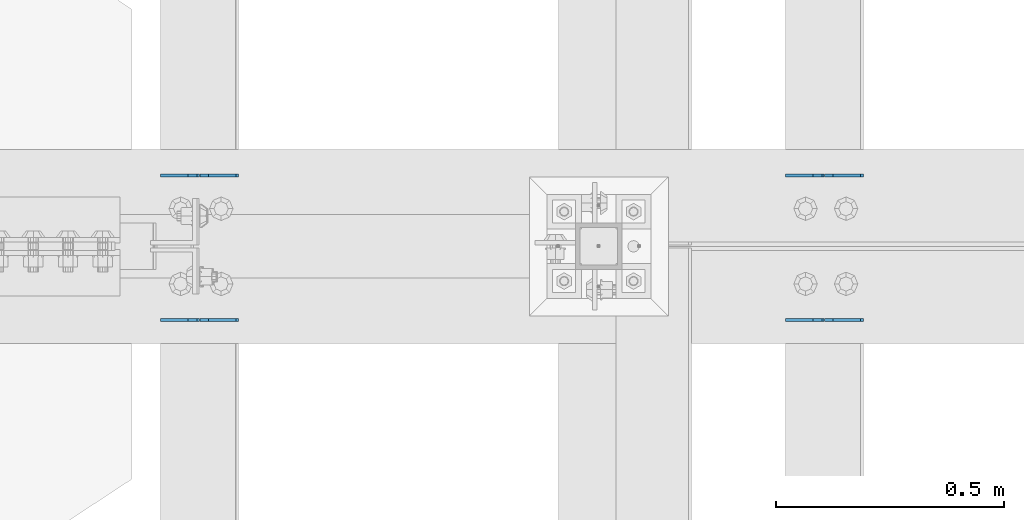
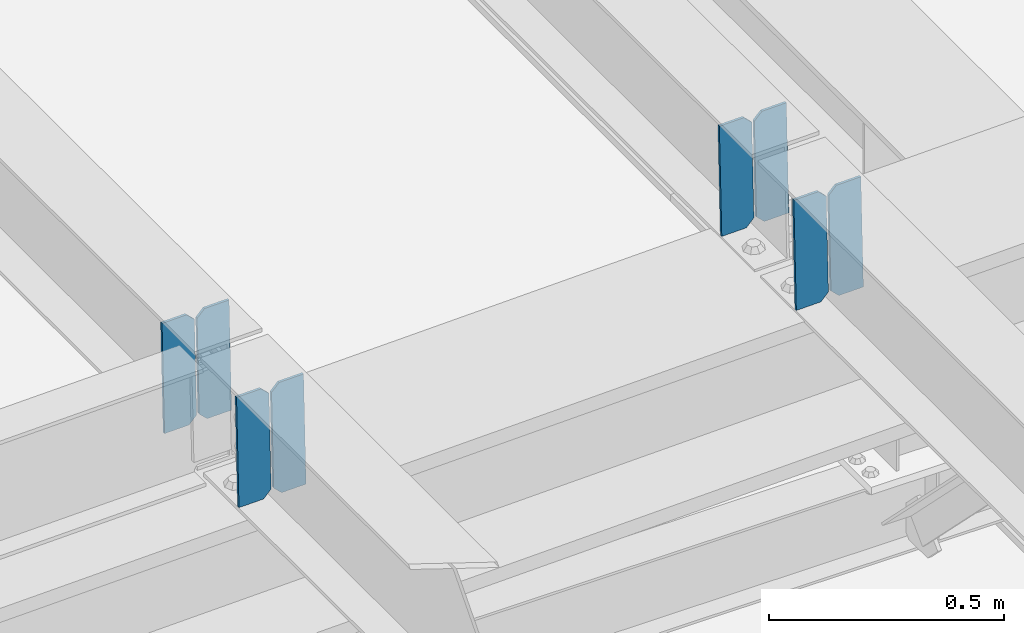
# One storey, part 3282 of 3843: 8 plates, 4 elements without a shape of their own.
"""IFC2X3 building model written with IfcOpenShell, lengths in millimetres."""

from ifc_helpers import new_model, si_unit, frame, origin_with_axes, place, context, subcontext, project, spatial, faceted_brep, material, type_object, element, aggregate, save


model = new_model("IFC2X3")

# Units and contexts
model_context = context("Model", 3, precision=1e-05, world=origin_with_axes())
body_context = subcontext(model_context, "Body", "Model", "MODEL_VIEW")
ifc_project = project(units=[si_unit("LENGTHUNIT", "METRE", prefix="MILLI"), si_unit("AREAUNIT", "SQUARE_METRE"), si_unit("VOLUMEUNIT", "CUBIC_METRE"), si_unit("MASSUNIT", "GRAM", prefix="KILO"), si_unit("TIMEUNIT", "SECOND"), si_unit("PLANEANGLEUNIT", "RADIAN"), si_unit("SOLIDANGLEUNIT", "STERADIAN"), si_unit("THERMODYNAMICTEMPERATUREUNIT", "DEGREE_CELSIUS"), si_unit("LUMINOUSINTENSITYUNIT", "LUMEN")], contexts=[model_context])

# Site, building, storey
site_placement = place(None, origin_with_axes())
site = spatial("IfcSite", under=ifc_project, at=site_placement, CompositionType="ELEMENT")
building_placement = place(site_placement, origin_with_axes())
building = spatial("IfcBuilding", under=site, at=building_placement, Name="Undefined", CompositionType="ELEMENT")
storey_placement = place(building_placement, origin_with_axes())
storey = spatial("IfcBuildingStorey", under=building, at=storey_placement, Name="Undefined", CompositionType="ELEMENT", Elevation=0.0)

# Assembly, plates
assembly_1_placement = place(storey_placement, origin_with_axes())
assembly_1 = element("IfcElementAssembly", 1, at=assembly_1_placement, inside=storey, Name="BEAM", AssemblyPlace="NOTDEFINED", PredefinedType="RIGID_FRAME")
ifc_material = material(Name="STEEL/A572-50")
plate_type = type_object("IfcPlateType", PredefinedType="NOTDEFINED")
plate_1_placement = place(assembly_1_placement, frame((39401.4964783277, 59071.0151888646, 45501.4258231306), z_axis=(-0.0211520983455921, -0.000470089999922493, 0.999776158823049), x_axis=(-0.999776269357268, 1.0337000006824e-05, -0.0211520950075907)))
plate_1 = element("IfcPlate", 2, at=plate_1_placement, type_object=plate_type, material=ifc_material, Name="PLATE", context=body_context, shape_type="Brep", body=[
    faceted_brep([(0.0, -3.17499999999927, 0.0), (6.83940015733242e-10, -3.17499999996653, 288.924999998613), (6.54836185276508e-10, 3.17500000001746, 288.924999998591), (0.0, 3.17499999999927, 0.0), (60.3250007643655, -3.17500000017753, 288.924999998606), (60.3250007643219, 3.17499999979918, 288.924999998584), (79.3750000013097, -3.17500000025029, 269.875000761494), (79.375000001266, 3.17499999972642, 269.875000761487), (79.375000000713, -3.17500000026484, 19.0499992370605), (79.3750000006985, 3.17499999971187, 19.0499992370533), (60.325000763667, -3.17500000020664, -1.45519152283669e-11), (60.3250007636234, 3.17499999977736, -3.63797880709171e-11)], [[[0, 1, 2, 3]], [[1, 4, 5, 2]], [[4, 6, 7, 5]], [[6, 8, 9, 7]], [[8, 10, 11, 9]], [[10, 0, 3, 11]], [[5, 7, 9, 11, 3, 2]], [[10, 8, 6, 4, 1, 0]]]),
])
plate_2_placement = place(assembly_1_placement, frame((39315.790657638, 59071.0160414519, 45499.61255973), z_axis=(-0.0211520983455921, -0.000470089999922493, 0.999776158823049), x_axis=(-0.999776269357268, 1.0337000006824e-05, -0.0211520950075907)))
plate_2 = element("IfcPlate", 3, at=plate_2_placement, type_object=plate_type, material=ifc_material, Name="PLATE", context=body_context, shape_type="Brep", body=[
    faceted_brep([(4.36557456851006e-11, -3.17499999998836, 19.0499992370969), (6.11180439591408e-10, -3.17499999996653, 269.875000761516), (5.96628524363041e-10, 3.17500000001746, 269.875000761502), (1.45519152283669e-11, 3.17499999998836, 19.0499992370824), (19.0499992376572, -3.17500000003201, 288.924999998606), (19.0499992376281, 3.1749999999447, 288.924999998584), (79.3750000013242, -3.17500000025029, 288.924999998591), (79.3750000013097, 3.1749999997337, 288.92499999857), (79.3750000006548, -3.17500000026484, -2.18278728425503e-11), (79.3750000006403, 3.17499999969732, -2.91038304567337e-11), (19.0499992370023, -3.17500000005384, 0.0), (19.0499992369587, 3.17499999992287, -1.45519152283669e-11)], [[[0, 1, 2, 3]], [[1, 4, 5, 2]], [[4, 6, 7, 5]], [[6, 8, 9, 7]], [[8, 10, 11, 9]], [[10, 0, 3, 11]], [[5, 7, 9, 11, 3, 2]], [[10, 8, 6, 4, 1, 0]]]),
])
aggregate(assembly_1, [plate_1, plate_2])

assembly_2_placement = place(storey_placement, origin_with_axes())
assembly_2 = element("IfcElementAssembly", 4, at=assembly_2_placement, inside=storey, Name="BEAM", AssemblyPlace="NOTDEFINED", PredefinedType="RIGID_FRAME")
plate_3_placement = place(assembly_2_placement, frame((39401.4964783163, 58753.2346579974, 45501.4288932269), z_axis=(-0.0211520983507508, 0.000470605999806139, 0.999776158580186), x_axis=(-0.999776269336729, -1.02780000340977e-05, -0.0211520960071139)))
plate_3 = element("IfcPlate", 5, at=plate_3_placement, type_object=plate_type, material=ifc_material, Name="PLATE", context=body_context, shape_type="Brep", body=[
    faceted_brep([(0.0, -3.17499999999927, 0.0), (6.83940015733242e-10, -3.17499999996653, 288.924999998613), (6.54836185276508e-10, 3.17500000001746, 288.924999998591), (0.0, 3.17499999999927, 0.0), (60.3250007643655, -3.17500000017753, 288.924999998606), (60.3250007643219, 3.17499999979918, 288.924999998584), (79.3750000013097, -3.17500000025029, 269.875000761494), (79.375000001266, 3.17499999972642, 269.875000761487), (79.375000000713, -3.17500000026484, 19.0499992370605), (79.3750000006985, 3.17499999971187, 19.0499992370533), (60.325000763667, -3.17500000020664, -1.45519152283669e-11), (60.3250007636234, 3.17499999977736, -3.63797880709171e-11)], [[[0, 1, 2, 3]], [[1, 4, 5, 2]], [[4, 6, 7, 5]], [[6, 8, 9, 7]], [[8, 10, 11, 9]], [[10, 0, 3, 11]], [[5, 7, 9, 11, 3, 2]], [[10, 8, 6, 4, 1, 0]]]),
])
plate_4_placement = place(assembly_2_placement, frame((39315.790657627, 58753.2338044747, 45499.6156298271), z_axis=(-0.0211520983507508, 0.000470605999806139, 0.999776158580186), x_axis=(-0.999776269336729, -1.02780000340977e-05, -0.0211520960071139)))
plate_4 = element("IfcPlate", 6, at=plate_4_placement, type_object=plate_type, material=ifc_material, Name="PLATE", context=body_context, shape_type="Brep", body=[
    faceted_brep([(4.36557456851006e-11, -3.17499999998836, 19.0499992370969), (6.11180439591408e-10, -3.17499999996653, 269.875000761516), (5.96628524363041e-10, 3.17500000001746, 269.875000761502), (1.45519152283669e-11, 3.17499999998836, 19.0499992370824), (19.0499992376572, -3.17500000003201, 288.924999998606), (19.0499992376281, 3.1749999999447, 288.924999998584), (79.3750000013242, -3.17500000025029, 288.924999998591), (79.3750000013097, 3.1749999997337, 288.92499999857), (79.3750000006548, -3.17500000026484, -2.18278728425503e-11), (79.3750000006403, 3.17499999969732, -2.91038304567337e-11), (19.0499992370023, -3.17500000005384, 0.0), (19.0499992369587, 3.17499999992287, -1.45519152283669e-11)], [[[0, 1, 2, 3]], [[1, 4, 5, 2]], [[4, 6, 7, 5]], [[6, 8, 9, 7]], [[8, 10, 11, 9]], [[10, 0, 3, 11]], [[5, 7, 9, 11, 3, 2]], [[10, 8, 6, 4, 1, 0]]]),
])
aggregate(assembly_2, [plate_3, plate_4])

assembly_3_placement = place(storey_placement, origin_with_axes())
assembly_3 = element("IfcElementAssembly", 7, at=assembly_3_placement, inside=storey, Name="BEAM", AssemblyPlace="NOTDEFINED", PredefinedType="RIGID_FRAME")
plate_5_placement = place(assembly_3_placement, frame((38029.8964783286, 59070.8690824421, 45468.5968295316), z_axis=(-0.021152098011531, 1.98379999928875e-05, 0.999776269150336), x_axis=(-0.999776270257024, 0.0, -0.0211520550054595)))
plate_5 = element("IfcPlate", 8, at=plate_5_placement, type_object=plate_type, material=ifc_material, Name="PLATE", context=body_context, shape_type="Brep", body=[
    faceted_brep([(0.0, -3.17499999999927, 0.0), (6.83940015733242e-10, -3.17499999996653, 288.924999998613), (6.54836185276508e-10, 3.17500000001746, 288.924999998591), (0.0, 3.17499999999927, 0.0), (60.3250007643655, -3.17500000017753, 288.924999998606), (60.3250007643219, 3.17499999979918, 288.924999998584), (79.3750000013097, -3.17500000025029, 269.875000761494), (79.375000001266, 3.17499999972642, 269.875000761487), (79.375000000713, -3.17500000026484, 19.0499992370605), (79.3750000006985, 3.17499999971187, 19.0499992370533), (60.325000763667, -3.17500000020664, -1.45519152283669e-11), (60.3250007636234, 3.17499999977736, -3.63797880709171e-11)], [[[0, 1, 2, 3]], [[1, 4, 5, 2]], [[4, 6, 7, 5]], [[6, 8, 9, 7]], [[8, 10, 11, 9]], [[10, 0, 3, 11]], [[5, 7, 9, 11, 3, 2]], [[10, 8, 6, 4, 1, 0]]]),
])
plate_6_placement = place(assembly_3_placement, frame((37944.190657639, 59070.8690464615, 45466.7835659307), z_axis=(-0.021152098011531, 1.98379999928875e-05, 0.999776269150336), x_axis=(-0.999776270257024, 0.0, -0.0211520550054595)))
plate_6 = element("IfcPlate", 9, at=plate_6_placement, type_object=plate_type, material=ifc_material, Name="PLATE", context=body_context, shape_type="Brep", body=[
    faceted_brep([(4.36557456851006e-11, -3.17499999998836, 19.0499992370969), (6.11180439591408e-10, -3.17499999996653, 269.875000761516), (5.96628524363041e-10, 3.17500000001746, 269.875000761502), (1.45519152283669e-11, 3.17499999998836, 19.0499992370824), (19.0499992376572, -3.17500000003201, 288.924999998606), (19.0499992376281, 3.1749999999447, 288.924999998584), (79.3750000013242, -3.17500000025029, 288.924999998591), (79.3750000013097, 3.1749999997337, 288.92499999857), (79.3750000006548, -3.17500000026484, -2.18278728425503e-11), (79.3750000006403, 3.17499999969732, -2.91038304567337e-11), (19.0499992370023, -3.17500000005384, 0.0), (19.0499992369587, 3.17499999992287, -1.45519152283669e-11)], [[[0, 1, 2, 3]], [[1, 4, 5, 2]], [[4, 6, 7, 5]], [[6, 8, 9, 7]], [[8, 10, 11, 9]], [[10, 0, 3, 11]], [[5, 7, 9, 11, 3, 2]], [[10, 8, 6, 4, 1, 0]]]),
])
aggregate(assembly_3, [plate_5, plate_6])

assembly_4_placement = place(storey_placement, origin_with_axes())
assembly_4 = element("IfcElementAssembly", 10, at=assembly_4_placement, inside=storey, Name="BEAM", AssemblyPlace="NOTDEFINED", PredefinedType="RIGID_FRAME")
plate_7_placement = place(assembly_4_placement, frame((38029.8964783165, 58753.3808405989, 45468.596748189), z_axis=(-0.0211520980113928, -1.95800000001327e-05, 0.999776269155425), x_axis=(-0.999776270257024, 0.0, -0.0211520550054595)))
plate_7 = element("IfcPlate", 11, at=plate_7_placement, type_object=plate_type, material=ifc_material, Name="PLATE", context=body_context, shape_type="Brep", body=[
    faceted_brep([(0.0, -3.17499999999927, 0.0), (6.83940015733242e-10, -3.17499999996653, 288.924999998613), (6.54836185276508e-10, 3.17500000001746, 288.924999998591), (0.0, 3.17499999999927, 0.0), (60.3250007643655, -3.17500000017753, 288.924999998606), (60.3250007643219, 3.17499999979918, 288.924999998584), (79.3750000013097, -3.17500000025029, 269.875000761494), (79.375000001266, 3.17499999972642, 269.875000761487), (79.375000000713, -3.17500000026484, 19.0499992370605), (79.3750000006985, 3.17499999971187, 19.0499992370533), (60.325000763667, -3.17500000020664, -1.45519152283669e-11), (60.3250007636234, 3.17499999977736, -3.63797880709171e-11)], [[[0, 1, 2, 3]], [[1, 4, 5, 2]], [[4, 6, 7, 5]], [[6, 8, 9, 7]], [[8, 10, 11, 9]], [[10, 0, 3, 11]], [[5, 7, 9, 11, 3, 2]], [[10, 8, 6, 4, 1, 0]]]),
])
plate_8_placement = place(assembly_4_placement, frame((37944.1906576272, 58753.3808761115, 45466.7834845884), z_axis=(-0.0211520980113928, -1.95800000001327e-05, 0.999776269155425), x_axis=(-0.999776270257024, 0.0, -0.0211520550054595)))
plate_8 = element("IfcPlate", 12, at=plate_8_placement, type_object=plate_type, material=ifc_material, Name="PLATE", context=body_context, shape_type="Brep", body=[
    faceted_brep([(4.36557456851006e-11, -3.17499999998836, 19.0499992370969), (6.11180439591408e-10, -3.17499999996653, 269.875000761516), (5.96628524363041e-10, 3.17500000001746, 269.875000761502), (1.45519152283669e-11, 3.17499999998836, 19.0499992370824), (19.0499992376572, -3.17500000003201, 288.924999998606), (19.0499992376281, 3.1749999999447, 288.924999998584), (79.3750000013242, -3.17500000025029, 288.924999998591), (79.3750000013097, 3.1749999997337, 288.92499999857), (79.3750000006548, -3.17500000026484, -2.18278728425503e-11), (79.3750000006403, 3.17499999969732, -2.91038304567337e-11), (19.0499992370023, -3.17500000005384, 0.0), (19.0499992369587, 3.17499999992287, -1.45519152283669e-11)], [[[0, 1, 2, 3]], [[1, 4, 5, 2]], [[4, 6, 7, 5]], [[6, 8, 9, 7]], [[8, 10, 11, 9]], [[10, 0, 3, 11]], [[5, 7, 9, 11, 3, 2]], [[10, 8, 6, 4, 1, 0]]]),
])
aggregate(assembly_4, [plate_7, plate_8])

save(model, "model.ifc")
